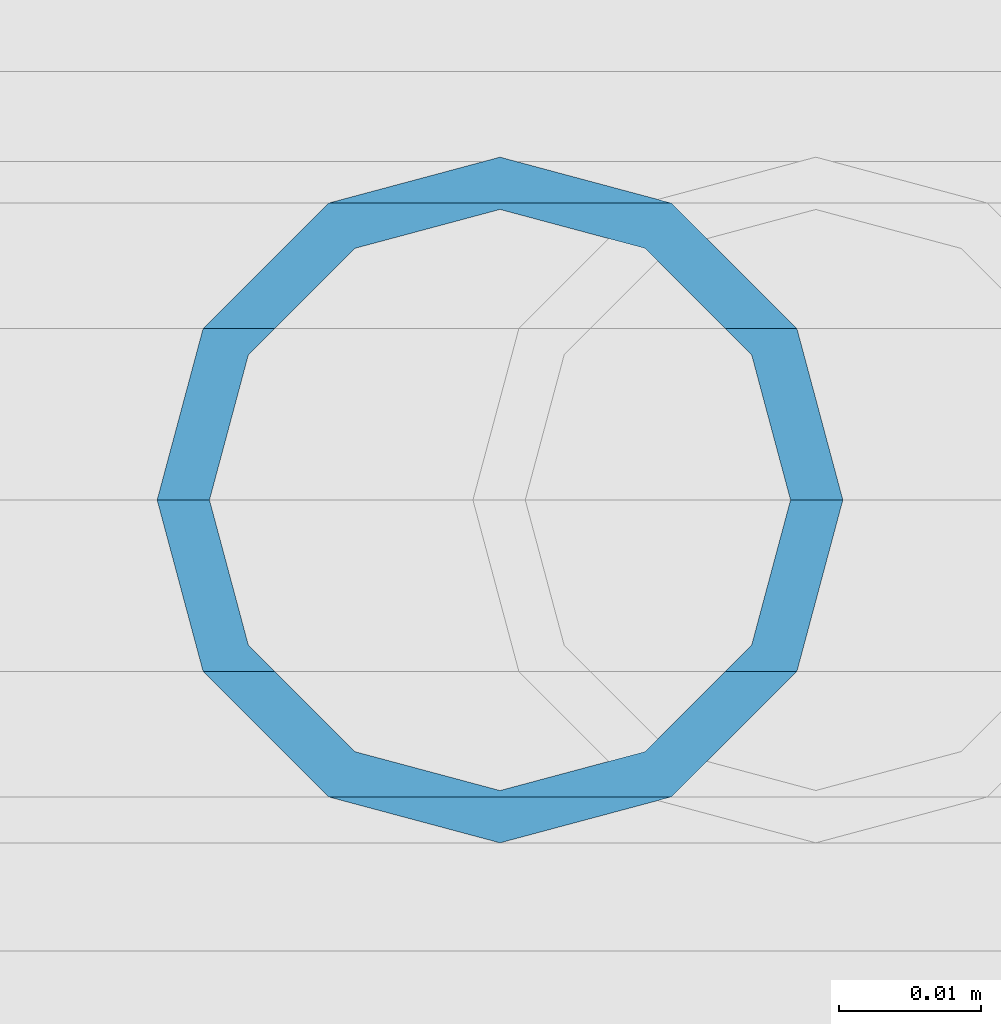
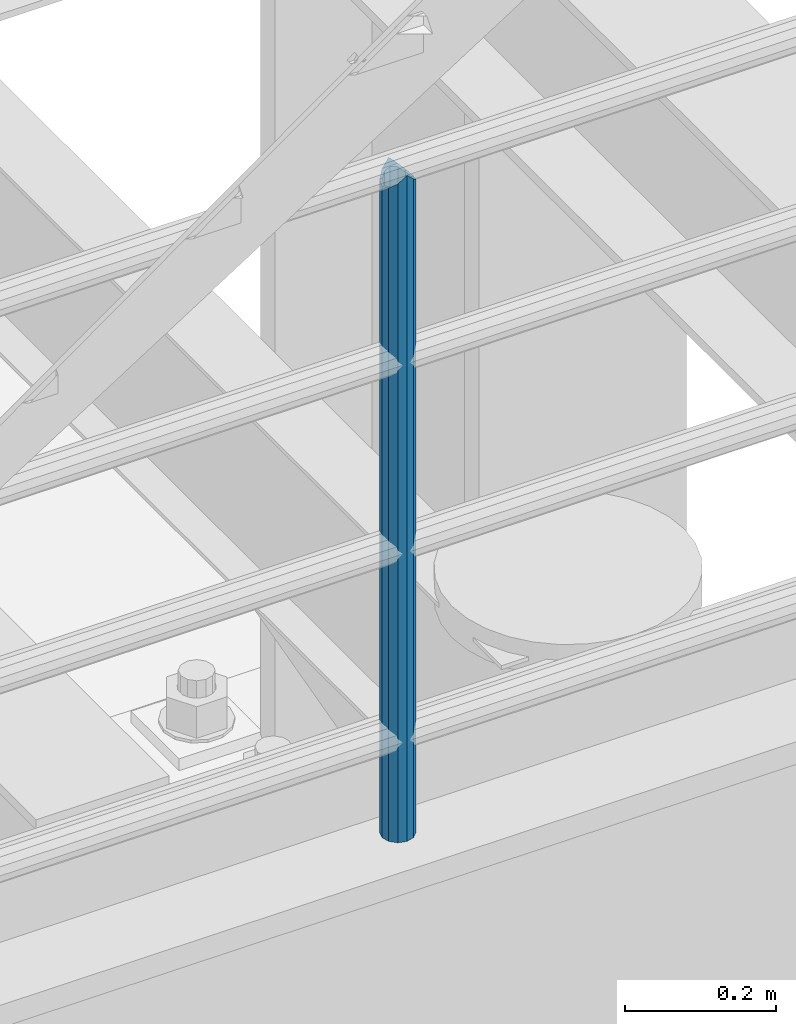
# One storey, part 630 of 1876: 1 column, 1 element without a shape of its own.
"""IFC2X3 building model written with IfcOpenShell, lengths in millimetres."""

from ifc_helpers import new_model, si_unit, frame, origin_with_axes, place, context, subcontext, project, spatial, faceted_brep, material, type_object, element, aggregate, save


model = new_model("IFC2X3")

# Units and contexts
model_context = context("Model", 3, precision=1e-05, world=origin_with_axes())
body_context = subcontext(model_context, "Body", "Model", "MODEL_VIEW")
ifc_project = project(units=[si_unit("LENGTHUNIT", "METRE", prefix="MILLI"), si_unit("AREAUNIT", "SQUARE_METRE"), si_unit("VOLUMEUNIT", "CUBIC_METRE"), si_unit("MASSUNIT", "GRAM", prefix="KILO"), si_unit("TIMEUNIT", "SECOND"), si_unit("PLANEANGLEUNIT", "RADIAN"), si_unit("SOLIDANGLEUNIT", "STERADIAN"), si_unit("THERMODYNAMICTEMPERATUREUNIT", "DEGREE_CELSIUS"), si_unit("LUMINOUSINTENSITYUNIT", "LUMEN")], contexts=[model_context])

# Site, building, storey
site_placement = place(None, origin_with_axes())
site = spatial("IfcSite", under=ifc_project, at=site_placement, CompositionType="ELEMENT")
building_placement = place(site_placement, origin_with_axes())
building = spatial("IfcBuilding", under=site, at=building_placement, Name="Undefined", CompositionType="ELEMENT")
storey_placement = place(building_placement, origin_with_axes())
storey = spatial("IfcBuildingStorey", under=building, at=storey_placement, Name="Undefined", CompositionType="ELEMENT", Elevation=0.0)

# Assembly, column
assembly_placement = place(storey_placement, origin_with_axes())
assembly = element("IfcElementAssembly", 1, at=assembly_placement, inside=storey, Name="RAIL", AssemblyPlace="NOTDEFINED", PredefinedType="RIGID_FRAME")
ifc_material = material()
column_type = type_object("IfcColumnType", Name="PIPE1-1/2SCH40", PredefinedType="NOTDEFINED")
column_placement = place(assembly_placement, frame((3937.0000001557, -4654.55000114554, 5130.8), z_axis=(1.0, 0.0, 0.0), x_axis=(0.0, 0.0, 1.0)))
column = element("IfcColumn", 2, at=column_placement, type_object=column_type, material=ifc_material, Name="POST", ObjectType="PIPE1-1/2SCH40", context=body_context, shape_type="Brep", body=[
    faceted_brep([(1055.42780700668, -12.0650000000001, 20.8971929933186), (1055.42780700668, -12.0650000000001, 15.8661214311805), (1054.93437856882, -10.2235000000001, 17.7076214311801), (1052.195, 0.0, 20.4470000000001), (1052.195, 0.0, 24.1300000000001), (1054.93437856882, 10.2235000000001, 17.7076214311801), (1055.42780700668, 12.0650000000001, 15.8661214311805), (1055.42780700668, 12.0650000000001, 20.8971929933186), (1076.325, 24.1300000000001, 0.0), (1064.26, 20.8971929933184, 12.0649999999996), (1064.25999999999, 20.8971929933186, -12.0649999999996), (1061.07042843786, 17.7076214311803, 10.2235000000001), (1063.80980700668, 20.4469999999999, 0.0), (1061.07042843786, 17.7076214311803, -10.2235000000001), (1055.42780700668, 12.0650000000001, -15.8661214311805), (1055.42780700667, 12.0649999999996, -20.8971929933186), (1054.93437856882, 10.2235000000001, -17.7076214311801), (1052.195, 0.0, -20.4470000000001), (1052.19499999999, 0.0, -24.1300000000001), (1055.42780700668, -12.0650000000001, -15.8661214311805), (1055.42780700667, -12.0649999999996, -20.8971929933186), (1054.93437856882, -10.2235000000001, -17.7076214311801), (1076.325, -24.1300000000001, 0.0), (1064.25999999999, -20.8971929933186, -12.0649999999996), (1064.26, -20.8971929933184, 12.0649999999996), (1061.07042843786, -17.7076214311803, -10.2235000000001), (1063.80980700668, -20.4469999999999, 0.0), (1061.07042843786, -17.7076214311803, 10.2235000000001), (0.0, -20.8971929933184, -12.0649999999996), (0.0, -12.0650000000001, -20.8971929933186), (-1.45519152283669e-11, 0.0, -24.130000000001), (0.0, 12.0650000000001, -20.8971929933186), (0.0, 20.8971929933184, -12.0649999999996), (0.0, 24.1299999999992, 0.0), (0.0, 20.8971929933184, 12.0649999999996), (0.0, 12.0650000000001, 20.8971929933186), (-1.45519152283669e-11, 0.0, 24.130000000001), (0.0, -12.0650000000001, 20.8971929933186), (0.0, -20.8971929933184, 12.0649999999996), (0.0, -24.1299999999992, 0.0), (0.0, -17.7076214311803, -10.2235000000001), (0.0, -10.2235000000001, -17.7076214311801), (-1.45519152283669e-11, 0.0, -20.4470000000001), (0.0, 10.2235000000001, -17.7076214311801), (0.0, 17.7076214311803, -10.2235000000001), (0.0, 20.4469999999999, 0.0), (0.0, 17.7076214311803, 10.2235000000001), (0.0, 10.2235000000001, 17.7076214311801), (-1.45519152283669e-11, 0.0, 20.4470000000001), (0.0, -10.2235000000001, 17.7076214311801), (0.0, -17.7076214311803, 10.2235000000001), (0.0, -20.4469999999999, 0.0)], [[[0, 1, 2, 3, 4]], [[4, 3, 5, 6, 7]], [[8, 9, 10]], [[7, 6, 11, 12, 13, 14, 15, 10, 9]], [[16, 17, 18, 15, 14]], [[19, 20, 18, 17, 21]], [[22, 23, 24]], [[24, 23, 20, 19, 25, 26, 27, 1, 0]], [[28, 29, 20, 23]], [[29, 30, 18, 20]], [[30, 31, 15, 18]], [[31, 32, 10, 15]], [[32, 33, 8, 10]], [[33, 34, 9, 8]], [[34, 35, 7, 9]], [[35, 36, 4, 7]], [[36, 37, 0, 4]], [[37, 38, 24, 0]], [[38, 39, 22, 24]], [[39, 28, 23, 22]], [[38, 37, 36, 35, 34, 33, 32, 31, 30, 29, 28, 39], [40, 41, 42, 43, 44, 45, 46, 47, 48, 49, 50, 51]], [[40, 51, 26, 25]], [[21, 41, 40, 25, 19]], [[42, 41, 21, 17]], [[43, 42, 17, 16]], [[44, 43, 16, 14, 13]], [[45, 44, 13, 12]], [[46, 45, 12, 11]], [[5, 47, 46, 11, 6]], [[48, 47, 5, 3]], [[49, 48, 3, 2]], [[50, 49, 2, 1, 27]], [[51, 50, 27, 26]]]),
])
aggregate(assembly, [column])

save(model, "model.ifc")
